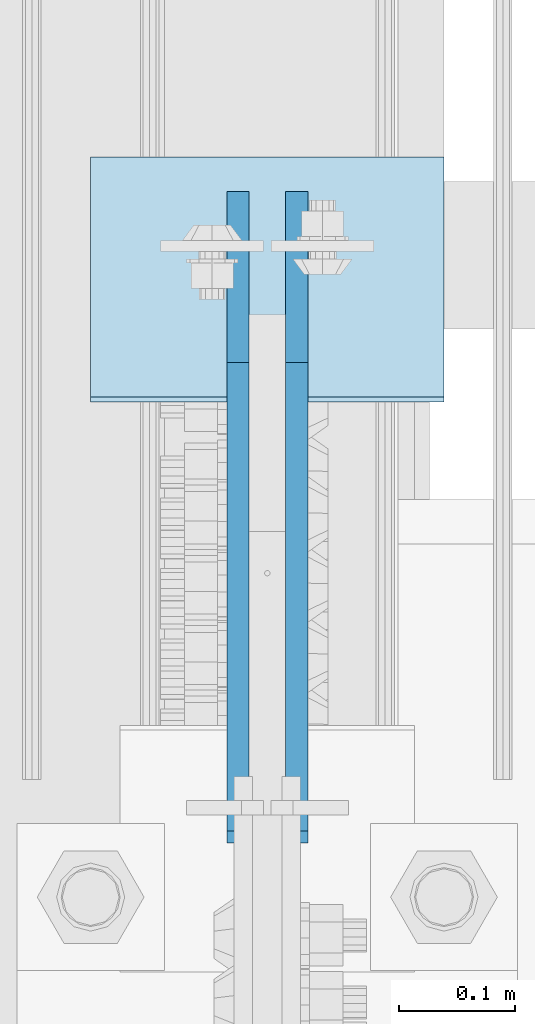
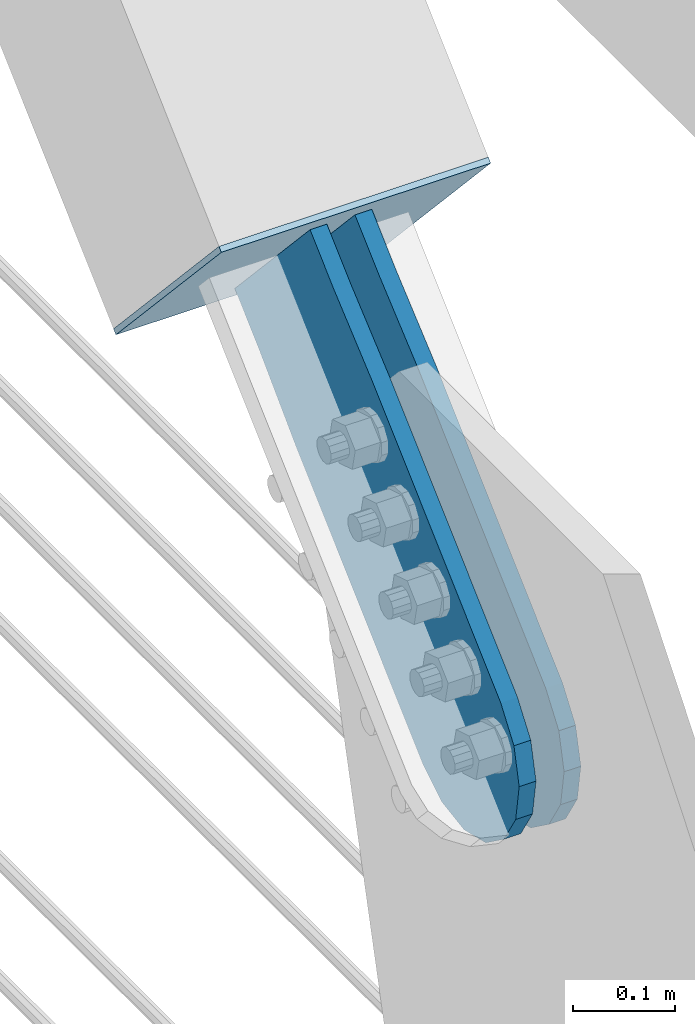
# One storey, part 3123 of 3843: 3 plates, 3 elements without a shape of their own.
"""IFC2X3 building model written with IfcOpenShell, lengths in millimetres."""

from ifc_helpers import new_model, si_unit, frame, origin_with_axes, place, context, subcontext, project, spatial, faceted_brep, material, type_object, element, aggregate, save


model = new_model("IFC2X3")

# Units and contexts
model_context = context("Model", 3, precision=1e-05, world=origin_with_axes())
body_context = subcontext(model_context, "Body", "Model", "MODEL_VIEW")
ifc_project = project(units=[si_unit("LENGTHUNIT", "METRE", prefix="MILLI"), si_unit("AREAUNIT", "SQUARE_METRE"), si_unit("VOLUMEUNIT", "CUBIC_METRE"), si_unit("MASSUNIT", "GRAM", prefix="KILO"), si_unit("TIMEUNIT", "SECOND"), si_unit("PLANEANGLEUNIT", "RADIAN"), si_unit("SOLIDANGLEUNIT", "STERADIAN"), si_unit("THERMODYNAMICTEMPERATUREUNIT", "DEGREE_CELSIUS"), si_unit("LUMINOUSINTENSITYUNIT", "LUMEN")], contexts=[model_context])

# Site, building, storey
site_placement = place(None, origin_with_axes())
site = spatial("IfcSite", under=ifc_project, at=site_placement, CompositionType="ELEMENT")
building_placement = place(site_placement, origin_with_axes())
building = spatial("IfcBuilding", under=site, at=building_placement, Name="Undefined", CompositionType="ELEMENT")
storey_placement = place(building_placement, origin_with_axes())
storey = spatial("IfcBuildingStorey", under=building, at=storey_placement, Name="Undefined", CompositionType="ELEMENT", Elevation=0.0)

# Assembly, plate
assembly_1_placement = place(storey_placement, origin_with_axes())
assembly_1 = element("IfcElementAssembly", 1, at=assembly_1_placement, inside=storey, AssemblyPlace="NOTDEFINED", PredefinedType="RIGID_FRAME")
ifc_material = material(Name="STEEL/A36")
plate_type_1 = type_object("IfcPlateType", PredefinedType="NOTDEFINED")
plate_1_placement = place(assembly_1_placement, frame((55905.4, 21372.6850659196, 30515.1205627884), z_axis=(0.0, -0.678193033067635, 0.734883807073283), x_axis=(0.0, 0.734883807073284, 0.678193033067634)))
plate_1 = element("IfcPlate", 2, at=plate_1_placement, type_object=plate_type_1, material=ifc_material, context=body_context, shape_type="Brep", body=[
    faceted_brep([(0.0, -9.52500000000146, 0.0), (-101.599999999984, -9.52500000000146, -3.96583768679466), (-101.599999999984, 9.52500000000146, -3.96583768679466), (0.0, 9.52500000000146, 0.0), (-441.169864341857, -9.52500000000146, -3.96583768679466), (-441.169864341857, 9.52500000000146, -3.96583768679466), (-484.303071296235, -9.52500000000146, 4.61389062117905), (-484.303071296235, 9.52500000000146, 4.61389062117905), (-520.8696384953, -9.52500000000146, 29.0468896856355), (-520.8696384953, 9.52500000000146, 29.0468896856355), (-545.302637559762, -9.52500000000146, 65.6134568847056), (-545.302637559762, 9.52500000000146, 65.6134568847056), (-553.882365867736, -9.52500000000146, 108.746660787315), (-553.882365867736, 9.52500000000146, 108.746660787315), (-545.302637559762, -9.52500000000146, 151.879867741693), (-545.302637559762, 9.52500000000146, 151.879867741693), (-520.8696384953, -9.52500000000146, 188.446434940764), (-520.8696384953, 9.52500000000146, 188.446434940764), (-484.303071296235, -9.52500000000146, 212.879434005224), (-484.303071296235, 9.52500000000146, 212.879434005224), (-441.169865867734, -9.52500000000146, 221.45916231319), (-441.169865867734, 9.52500000000146, 221.45916231319), (-101.599999999969, -9.52500000000146, 221.459162313185), (-101.599999999969, 9.52500000000146, 221.459162313185), (1.06956576928496e-09, -9.52500000000146, 217.493324627542), (1.06956576928496e-09, 9.52500000000146, 217.493324627542), (69.8500000010463, -9.52500000000146, 217.493324627546), (69.8500000010463, 9.52500000000146, 217.493324627546), (69.8499999979995, -9.52499999999418, -4.00177668780088e-10), (69.8499999979995, 9.52499999999418, -4.00177668780088e-10)], [[[0, 1, 2, 3]], [[1, 4, 5, 2]], [[4, 6, 7, 5]], [[6, 8, 9, 7]], [[8, 10, 11, 9]], [[10, 12, 13, 11]], [[12, 14, 15, 13]], [[14, 16, 17, 15]], [[16, 18, 19, 17]], [[18, 20, 21, 19]], [[20, 22, 23, 21]], [[22, 24, 25, 23]], [[24, 26, 27, 25]], [[26, 28, 29, 27]], [[28, 0, 3, 29]], [[5, 7, 9, 11, 13, 15, 17, 19, 21, 23, 25, 27, 29, 3, 2]], [[28, 26, 24, 22, 20, 18, 16, 14, 12, 10, 8, 6, 4, 1, 0]]]),
])
aggregate(assembly_1, [plate_1])

assembly_2_placement = place(storey_placement, origin_with_axes())
assembly_2 = element("IfcElementAssembly", 3, at=assembly_2_placement, inside=storey, AssemblyPlace="NOTDEFINED", PredefinedType="RIGID_FRAME")
plate_2_placement = place(assembly_2_placement, frame((55956.2, 21372.6850659196, 30515.1205627884), z_axis=(0.0, -0.678193033067635, 0.734883807073283), x_axis=(0.0, 0.734883807073284, 0.678193033067634)))
plate_2 = element("IfcPlate", 4, at=plate_2_placement, type_object=plate_type_1, material=ifc_material, context=body_context, shape_type="Brep", body=[
    faceted_brep([(0.0, -9.52500000000146, 0.0), (-101.599999999984, -9.52500000000146, -3.96583768679466), (-101.599999999984, 9.52500000000146, -3.96583768679466), (0.0, 9.52500000000146, 0.0), (-441.169864341857, -9.52500000000146, -3.96583768679466), (-441.169864341857, 9.52500000000146, -3.96583768679466), (-484.303071296235, -9.52500000000146, 4.61389062117905), (-484.303071296235, 9.52500000000146, 4.61389062117905), (-520.8696384953, -9.52500000000146, 29.0468896856355), (-520.8696384953, 9.52500000000146, 29.0468896856355), (-545.302637559762, -9.52500000000146, 65.6134568847056), (-545.302637559762, 9.52500000000146, 65.6134568847056), (-553.882365867736, -9.52500000000146, 108.746660787315), (-553.882365867736, 9.52500000000146, 108.746660787315), (-545.302637559762, -9.52500000000146, 151.879867741693), (-545.302637559762, 9.52500000000146, 151.879867741693), (-520.8696384953, -9.52500000000146, 188.446434940764), (-520.8696384953, 9.52500000000146, 188.446434940764), (-484.303071296235, -9.52500000000146, 212.879434005224), (-484.303071296235, 9.52500000000146, 212.879434005224), (-441.169865867734, -9.52500000000146, 221.45916231319), (-441.169865867734, 9.52500000000146, 221.45916231319), (-101.599999999969, -9.52500000000146, 221.459162313185), (-101.599999999969, 9.52500000000146, 221.459162313185), (1.06956576928496e-09, -9.52500000000146, 217.493324627542), (1.06956576928496e-09, 9.52500000000146, 217.493324627542), (69.8500000010463, -9.52500000000146, 217.493324627546), (69.8500000010463, 9.52500000000146, 217.493324627546), (69.8499999979995, -9.52499999999418, -4.00177668780088e-10), (69.8499999979995, 9.52499999999418, -4.00177668780088e-10)], [[[0, 1, 2, 3]], [[1, 4, 5, 2]], [[4, 6, 7, 5]], [[6, 8, 9, 7]], [[8, 10, 11, 9]], [[10, 12, 13, 11]], [[12, 14, 15, 13]], [[14, 16, 17, 15]], [[16, 18, 19, 17]], [[18, 20, 21, 19]], [[20, 22, 23, 21]], [[22, 24, 25, 23]], [[24, 26, 27, 25]], [[26, 28, 29, 27]], [[28, 0, 3, 29]], [[5, 7, 9, 11, 13, 15, 17, 19, 21, 23, 25, 27, 29, 3, 2]], [[28, 26, 24, 22, 20, 18, 16, 14, 12, 10, 8, 6, 4, 1, 0]]]),
])
aggregate(assembly_2, [plate_2])

assembly_3_placement = place(storey_placement, origin_with_axes())
assembly_3 = element("IfcElementAssembly", 5, at=assembly_3_placement, inside=storey, Name="Plate", AssemblyPlace="NOTDEFINED", PredefinedType="RIGID_FRAME")
plate_type_2 = type_object("IfcPlateType", PredefinedType="NOTDEFINED")
plate_3_placement = place(assembly_3_placement, frame((56083.2, 21451.2888332458, 30528.2589522776), z_axis=(0.0, -0.678193033067635, 0.734883807073283), x_axis=(-1.0, 0.0, 0.0)))
plate_3 = element("IfcPlate", 6, at=plate_3_placement, type_object=plate_type_2, material=ifc_material, Name="Plate", context=body_context, shape_type="Brep", body=[
    faceted_brep([(0.0, -3.17499999999927, 0.0), (0.0, -3.17499999999927, 304.800000000003), (0.0, 3.17499999999927, 304.800000000003), (0.0, 3.17499999999927, 0.0), (304.800000000003, -3.17500000019936, 304.800000010334), (304.800000000003, 3.17499999980646, 304.800000010323), (304.800000000003, -3.17500000000291, 2.72848410531878e-12), (304.800000000003, 3.17499999999563, -4.54747350886464e-12)], [[[0, 1, 2, 3]], [[1, 4, 5, 2]], [[4, 6, 7, 5]], [[6, 0, 3, 7]], [[5, 7, 3, 2]], [[6, 4, 1, 0]]]),
])
aggregate(assembly_3, [plate_3])

save(model, "model.ifc")
